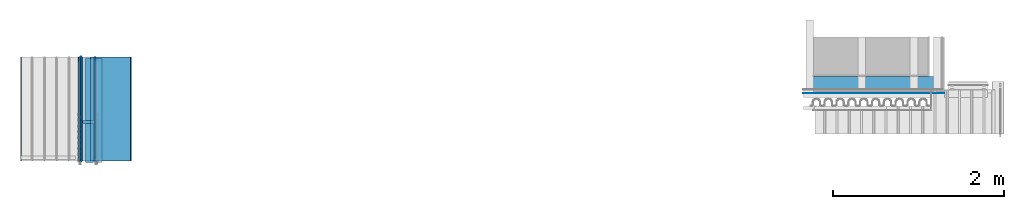
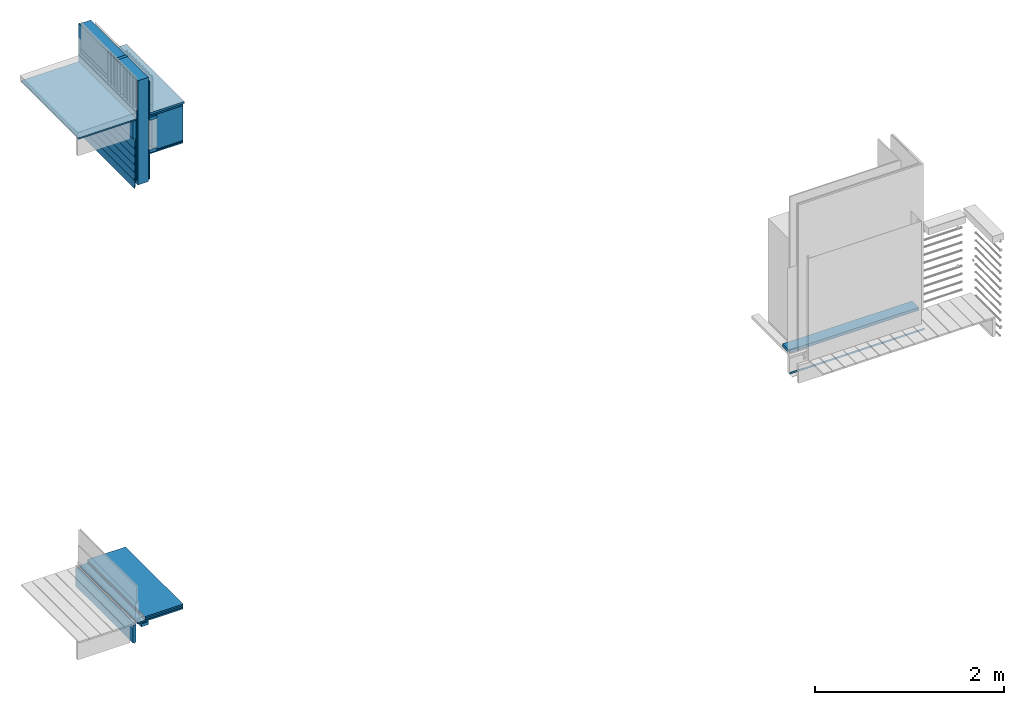
# One storey, part 1 of 33: 29 walls.
"""IFC4 building model written with IfcOpenShell, lengths in feet."""

from ifc_helpers import new_model, entity, si_unit, converted_unit, derived_unit, direction, frame, frame_2d, origin, origin_2d_with_axis, place, context, subcontext, project, spatial, rectangle, extrude, material, type_object, element, save


model = new_model("IFC4")

# Units and contexts
model_context = context("Model", 3, precision=0.0001, world=origin(), true_north=direction((6.12303176911189e-17, 1.0)))
body_context = subcontext(model_context, "Body", "Model", "MODEL_VIEW")
ifc_project = project(units=[converted_unit("LENGTHUNIT", "FOOT", entity("IfcRatioMeasure", 0.3048), si_unit("LENGTHUNIT", "METRE"), dimensions=[1, 0, 0, 0, 0, 0, 0]), converted_unit("AREAUNIT", "SQUARE FOOT", entity("IfcRatioMeasure", 0.09290304), si_unit("AREAUNIT", "SQUARE_METRE"), dimensions=[2, 0, 0, 0, 0, 0, 0]), converted_unit("VOLUMEUNIT", "CUBIC FOOT", entity("IfcRatioMeasure", 0.028316846592), si_unit("VOLUMEUNIT", "CUBIC_METRE"), dimensions=[3, 0, 0, 0, 0, 0, 0]), converted_unit("PLANEANGLEUNIT", "DEGREE", entity("IfcRatioMeasure", 0.0174532925199433), si_unit("PLANEANGLEUNIT", "RADIAN"), dimensions=[0, 0, 0, 0, 0, 0, 0]), si_unit("MASSUNIT", "GRAM", prefix="KILO"), derived_unit("MASSDENSITYUNIT", [(si_unit("MASSUNIT", "GRAM", prefix="KILO"), 1), (si_unit("LENGTHUNIT", "METRE"), -3)]), derived_unit("MOMENTOFINERTIAUNIT", [(si_unit("LENGTHUNIT", "METRE"), 4)]), si_unit("TIMEUNIT", "SECOND"), si_unit("FREQUENCYUNIT", "HERTZ"), si_unit("THERMODYNAMICTEMPERATUREUNIT", "DEGREE_CELSIUS"), derived_unit("THERMALTRANSMITTANCEUNIT", [(si_unit("MASSUNIT", "GRAM", prefix="KILO"), 1), (si_unit("THERMODYNAMICTEMPERATUREUNIT", "KELVIN"), -1), (si_unit("TIMEUNIT", "SECOND"), -3)]), derived_unit("VOLUMETRICFLOWRATEUNIT", [(si_unit("LENGTHUNIT", "METRE"), 3), (si_unit("TIMEUNIT", "SECOND"), -1)]), si_unit("ELECTRICCURRENTUNIT", "AMPERE"), si_unit("ELECTRICVOLTAGEUNIT", "VOLT"), si_unit("POWERUNIT", "WATT"), si_unit("FORCEUNIT", "NEWTON"), si_unit("ILLUMINANCEUNIT", "LUX"), si_unit("LUMINOUSFLUXUNIT", "LUMEN"), si_unit("LUMINOUSINTENSITYUNIT", "CANDELA"), derived_unit("USERDEFINED", [(si_unit("MASSUNIT", "GRAM", prefix="KILO"), -1), (si_unit("LENGTHUNIT", "METRE"), -2), (si_unit("TIMEUNIT", "SECOND"), 3), (si_unit("LUMINOUSFLUXUNIT", "LUMEN"), 1)]), derived_unit("LINEARVELOCITYUNIT", [(si_unit("LENGTHUNIT", "METRE"), 1), (si_unit("TIMEUNIT", "SECOND"), -1)]), si_unit("PRESSUREUNIT", "PASCAL"), derived_unit("USERDEFINED", [(si_unit("LENGTHUNIT", "METRE"), -2), (si_unit("MASSUNIT", "GRAM", prefix="KILO"), 1), (si_unit("TIMEUNIT", "SECOND"), -2)]), derived_unit("LINEARFORCEUNIT", [(si_unit("MASSUNIT", "GRAM", prefix="KILO"), 1), (si_unit("LENGTHUNIT", "METRE"), 1), (si_unit("TIMEUNIT", "SECOND"), -2), (si_unit("LENGTHUNIT", "METRE"), -1)]), derived_unit("PLANARFORCEUNIT", [(si_unit("MASSUNIT", "GRAM", prefix="KILO"), 1), (si_unit("LENGTHUNIT", "METRE"), 1), (si_unit("TIMEUNIT", "SECOND"), -2), (si_unit("LENGTHUNIT", "METRE"), -2)])], contexts=[model_context])

# Site, building, storey
site_placement = place(None, origin())
site = spatial("IfcSite", under=ifc_project, at=site_placement, CompositionType="ELEMENT")
building_placement = place(site_placement, origin())
building = spatial("IfcBuilding", under=site, at=building_placement, CompositionType="ELEMENT")
storey_placement = place(building_placement, frame((0.0, 0.0, 10.0)))
storey = spatial("IfcBuildingStorey", under=building, at=storey_placement, Name="2ND FLOOR", CompositionType="ELEMENT", Elevation=10.0000000000002)

# Walls
ifc_material_1 = material(Name="2X10 LEDGER - STAIN BEFORE INSTALL", Category="Materials")
wall_type_1 = type_object("IfcWallType", Name="Walls 14:Walls 13", PredefinedType="NOTDEFINED", material=ifc_material_1)
wall_1_placement = place(storey_placement, frame((1459.13314342118, 2.0, -0.136150105919342), z_axis=(0.0, 0.0, 1.0), x_axis=(0.0, 1.0, 0.0)))
element("IfcWall", 1, at=wall_1_placement, inside=storey, type_object=wall_type_1, material=ifc_material_1, Name="Walls 14:Walls 13", ObjectType="Walls 14:Walls 13", PredefinedType="NOTDEFINED", context=body_context, shape_type="SweptSolid", body=[
    extrude(rectangle(XDim=4.0, YDim=0.125, at=origin_2d_with_axis()), frame((2.0, -0.0625, 0.0)), (0.0, 0.0, 1.0), 0.749058960190016),
])
ifc_material_2 = material(Name="3/4 HARDWOOD FLOOR", Category="Materials")
wall_type_2 = type_object("IfcWallType", Name="Generic Models 624:Generic Models 1", PredefinedType="NOTDEFINED", material=ifc_material_2)
wall_2_placement = place(storey_placement, frame((1459.61600363951, 2.0, 0.749462449470961), z_axis=(0.0, 0.0, 1.0), x_axis=(0.0, 1.0, 0.0)))
element("IfcWall", 2, at=wall_2_placement, inside=storey, type_object=wall_type_2, material=ifc_material_2, Name="Generic Models 624:Generic Models 1", ObjectType="Generic Models 624:Generic Models 1", PredefinedType="NOTDEFINED", context=body_context, shape_type="SweptSolid", body=[
    extrude(rectangle(XDim=4.0, YDim=1.53135841010771, at=origin_2d_with_axis()), frame((2.0, -0.765679205053857, 0.0)), (0.0, 0.0, 1.0), 0.0625000000000053),
])
ifc_material_3 = material(Category="Materials")
wall_type_3 = type_object("IfcWallType", Name="Generic Models 642:Generic Models 1", PredefinedType="NOTDEFINED", material=ifc_material_3)
wall_3_placement = place(storey_placement, frame((1459.61600363951, 2.0, 0.686962449470574), z_axis=(0.0, 0.0, 1.0), x_axis=(0.0, 1.0, 0.0)))
element("IfcWall", 3, at=wall_3_placement, inside=storey, type_object=wall_type_3, material=ifc_material_3, Name="Generic Models 642:Generic Models 1", ObjectType="Generic Models 642:Generic Models 1", PredefinedType="NOTDEFINED", context=body_context, shape_type="SweptSolid", body=[
    extrude(rectangle(XDim=4.0, YDim=1.53135841010771, at=origin_2d_with_axis()), frame((2.0, -0.765679205053857, 0.0)), (0.0, 0.0, 1.0), 0.0625000000005151),
])
ifc_material_4 = material(Category="Materials")
wall_type_4 = type_object("IfcWallType", Name="Generic Models 644:Generic Models 1", PredefinedType="NOTDEFINED", material=ifc_material_4)
wall_4_placement = place(storey_placement, frame((1459.61138299712, 2.0, 0.669700544542543), z_axis=(0.0, 0.0, 1.0), x_axis=(0.0, 1.0, 0.0)))
element("IfcWall", 4, at=wall_4_placement, inside=storey, type_object=wall_type_4, material=ifc_material_4, Name="Generic Models 644:Generic Models 1", ObjectType="Generic Models 644:Generic Models 1", PredefinedType="NOTDEFINED", context=body_context, shape_type="SweptSolid", body=[
    extrude(rectangle(XDim=4.0, YDim=1.53597905249967, at=frame_2d((0.0, -1.13686837721616e-13), x_axis=(1.0, 0.0))), frame((2.0, -0.767989526249721, 0.0)), (0.0, 0.0, 1.0), 0.0104166666666679),
])
ifc_material_5 = material(Category="Materials")
wall_type_5 = type_object("IfcWallType", Name="Generic Models 659:Generic Models 1", PredefinedType="NOTDEFINED", material=ifc_material_5)
wall_5_placement = place(storey_placement, frame((1459.31114828999, 2.0, 0.604710198242904), z_axis=(0.0, 0.0, 1.0), x_axis=(0.0, 1.0, 0.0)))
element("IfcWall", 5, at=wall_5_placement, inside=storey, type_object=wall_type_5, material=ifc_material_5, Name="Generic Models 659:Generic Models 1", ObjectType="Generic Models 659:Generic Models 1", PredefinedType="NOTDEFINED", context=body_context, shape_type="SweptSolid", body=[
    extrude(rectangle(XDim=4.0, YDim=1.83621375963094, at=frame_2d((0.0, 2.27373675443232e-13), x_axis=(1.0, 0.0))), frame((2.0, -0.918106879815696, 0.0)), (0.0, 0.0, 1.0), 0.0625000000005169),
])
ifc_material_6 = material(Name="2X WOOD STUD", Category="Materials")
wall_type_6 = type_object("IfcWallType", Name="Generic Models 666:Generic Models 1", PredefinedType="NOTDEFINED", material=ifc_material_6)
wall_6_placement = place(storey_placement, frame((1459.31080872048, 3.44270833332939, 19.1970652408911)))
element("IfcWall", 6, at=wall_6_placement, inside=storey, type_object=wall_type_6, material=ifc_material_6, Name="Generic Models 666:Generic Models 1", ObjectType="Generic Models 666:Generic Models 1", PredefinedType="NOTDEFINED", context=body_context, shape_type="SweptSolid", body=[
    extrude(rectangle(XDim=0.125000000000001, YDim=0.458333333333485, at=frame_2d((-4.44089209850063e-16, 0.0), x_axis=(1.0, 0.0))), frame((0.229166666666742, 0.0625000000000022, 0.0), z_axis=(0.0, 0.0, 1.0), x_axis=(0.0, 1.0, 0.0)), (0.0, 0.0, 1.0), 4.4188083397401),
])
ifc_material_7 = material(Category="Materials")
wall_type_7 = type_object("IfcWallType", Name="Generic Models 701:Generic Models 1", PredefinedType="NOTDEFINED", material=ifc_material_7)
wall_7_placement = place(storey_placement, frame((1459.8987276705, 2.0, 20.4539793178762), z_axis=(0.0, 0.0, 1.0), x_axis=(0.0, 1.0, 0.0)))
element("IfcWall", 7, at=wall_7_placement, inside=storey, type_object=wall_type_7, material=ifc_material_7, Name="Generic Models 701:Generic Models 1", ObjectType="Generic Models 701:Generic Models 1", PredefinedType="NOTDEFINED", context=body_context, shape_type="SweptSolid", body=[
    extrude(rectangle(XDim=3.99999999999999, YDim=1.24863437911949, at=frame_2d((4.44089209850063e-16, -1.13686837721616e-13), x_axis=(1.0, 0.0))), frame((2.0, -0.624317189559633, 0.0)), (0.0, 0.0, 1.0), 1.47533404831026),
])
ifc_material_8 = material(Category="Materials")
wall_type_8 = type_object("IfcWallType", Name="Generic Models 702:Generic Models 1", PredefinedType="NOTDEFINED", material=ifc_material_8)
wall_8_placement = place(storey_placement, frame((1459.76914205382, 2.0, 19.2803985742244), z_axis=(0.0, 0.0, 1.0), x_axis=(0.0, 1.0, 0.0)))
element("IfcWall", 8, at=wall_8_placement, inside=storey, type_object=wall_type_8, material=ifc_material_8, Name="Generic Models 702:Generic Models 1", ObjectType="Generic Models 702:Generic Models 1", PredefinedType="NOTDEFINED", context=body_context, shape_type="SweptSolid", body=[
    extrude(rectangle(XDim=4.0, YDim=0.0520833333334849, at=frame_2d((2.22044604925031e-16, 0.0), x_axis=(1.0, 0.0))), frame((2.0, -0.0260416666667425, 0.0)), (0.0, 0.0, 1.0), 1.15710142577515),
])
wall_type_9 = type_object("IfcWallType", Name="Walls 17:Walls 13", PredefinedType="NOTDEFINED", material=ifc_material_1)
wall_9_placement = place(storey_placement, frame((1459.13314342118, 2.0, 21.2090806846188), z_axis=(0.0, 0.0, 1.0), x_axis=(0.0, 1.0, 0.0)))
element("IfcWall", 9, at=wall_9_placement, inside=storey, type_object=wall_type_9, material=ifc_material_1, Name="Walls 17:Walls 13", ObjectType="Walls 17:Walls 13", PredefinedType="NOTDEFINED", context=body_context, shape_type="SweptSolid", body=[
    extrude(rectangle(XDim=4.0, YDim=0.125, at=frame_2d((-2.22044604925031e-16, 0.0), x_axis=(1.0, 0.0))), frame((2.0, -0.0625, 0.0)), (0.0, 0.0, 1.0), 0.749058960190016),
])
ifc_material_9 = material(Category="Materials")
wall_type_10 = type_object("IfcWallType", Name="Generic Models 709:Generic Models 1", PredefinedType="NOTDEFINED", material=ifc_material_9)
wall_10_placement = place(storey_placement, frame((1459.81080872048, 2.0, 22.0005435315769), z_axis=(0.0, 0.0, 1.0), x_axis=(0.0, 1.0, 0.0)))
element("IfcWall", 10, at=wall_10_placement, inside=storey, type_object=wall_type_10, material=ifc_material_9, Name="Generic Models 709:Generic Models 1", ObjectType="Generic Models 709:Generic Models 1", PredefinedType="NOTDEFINED", context=body_context, shape_type="SweptSolid", body=[
    extrude(rectangle(XDim=4.0, YDim=1.37821999580547, at=frame_2d((2.22044604925031e-16, 0.0), x_axis=(1.0, 0.0))), frame((2.0, -0.689109997902733, 0.0)), (0.0, 0.0, 1.0), 0.0833333333333286),
])
ifc_material_10 = material(Name="FIBER CEMENT", Category="Materials")
wall_type_11 = type_object("IfcWallType", Name="Generic Models 717:Generic Models 1", PredefinedType="NOTDEFINED", material=ifc_material_10)
wall_11_placement = place(storey_placement, frame((1459.1949158051, 2.0, 20.7589183669021), z_axis=(0.0, 0.0, 1.0), x_axis=(0.0, 1.0, 0.0)))
element("IfcWall", 11, at=wall_11_placement, inside=storey, type_object=wall_type_11, material=ifc_material_10, Name="Generic Models 717:Generic Models 1", ObjectType="Generic Models 717:Generic Models 1", PredefinedType="NOTDEFINED", context=body_context, shape_type="SweptSolid", body=[
    extrude(rectangle(XDim=0.0259999999998033, YDim=4.0, at=frame_2d((1.11022302462516e-16, 0.0), x_axis=(0.0, 1.0))), frame((2.0, -0.0129531737923116, 0.0011024013350962), z_axis=(0.0, -0.0848001027000761, 0.99639798403151), x_axis=(1.0, 0.0, 0.0)), (0.0, 0.0, 1.0), 0.437499999999988),
])
ifc_material_11 = material(Category="Materials")
wall_type_12 = type_object("IfcWallType", Name="Generic Models 722:Generic Models 1", PredefinedType="NOTDEFINED", material=ifc_material_11)
wall_12_placement = place(storey_placement, frame((1459.82122538715, 2.0, 20.343749999999), z_axis=(0.0, 0.0, 1.0), x_axis=(0.0, 1.0, 0.0)))
element("IfcWall", 12, at=wall_12_placement, inside=storey, type_object=wall_type_12, material=ifc_material_11, Name="Generic Models 722:Generic Models 1", ObjectType="Generic Models 722:Generic Models 1", PredefinedType="NOTDEFINED", context=body_context, shape_type="SweptSolid", body=[
    extrude(rectangle(XDim=4.0, YDim=1.32613666247244, at=frame_2d((2.22044604925031e-16, 0.0), x_axis=(1.0, 0.0))), frame((2.0, -0.663068331236218, 0.0)), (0.0, 0.0, 1.0), 0.0520833333333712),
])
ifc_material_12 = material(Category="Materials")
wall_type_13 = type_object("IfcWallType", Name="Generic Models 723:Generic Models 1", PredefinedType="NOTDEFINED", material=ifc_material_12)
wall_13_placement = place(storey_placement, frame((1459.26914205382, 2.0, 19.4172960314291), z_axis=(0.0, 0.0, 1.0), x_axis=(0.0, 1.0, 0.0)))
element("IfcWall", 13, at=wall_13_placement, inside=storey, type_object=wall_type_13, material=ifc_material_12, Name="Generic Models 723:Generic Models 1", ObjectType="Generic Models 723:Generic Models 1", PredefinedType="NOTDEFINED", context=body_context, shape_type="SweptSolid", body=[
    extrude(rectangle(XDim=4.0, YDim=0.0416666666667425, at=frame_2d((-4.44089209850063e-16, -1.13686837721616e-13), x_axis=(1.0, 0.0))), frame((2.0, -0.0208333333332575, 0.0)), (0.0, 0.0, 1.0), 4.2248209060622),
])
ifc_material_13 = material(Name="BATT INSULATION - FILL CAVITY", Category="Materials")
wall_type_14 = type_object("IfcWallType", Name="Generic Models 724:Generic Models 1", PredefinedType="NOTDEFINED", material=ifc_material_13)
wall_14_placement = place(storey_placement, frame((1459.33173871609, 2.0, 19.1970652408911), z_axis=(0.0, 0.0, 1.0), x_axis=(0.0, 1.0, 0.0)))
element("IfcWall", 14, at=wall_14_placement, inside=storey, type_object=wall_type_14, material=ifc_material_13, Name="Generic Models 724:Generic Models 1", ObjectType="Generic Models 724:Generic Models 1", PredefinedType="NOTDEFINED", context=body_context, shape_type="SweptSolid", body=[
    extrude(rectangle(XDim=4.00000000000001, YDim=0.416570004389314, at=frame_2d((-4.44089209850063e-16, -1.13686837721616e-13), x_axis=(1.0, 0.0))), frame((2.0, -0.208285002194543, 0.0)), (0.0, 0.0, 1.0), 4.41880833974011),
])
ifc_material_14 = material(Category="Materials")
wall_type_15 = type_object("IfcWallType", Name="Generic Models 729:Generic Models 1", PredefinedType="NOTDEFINED", material=ifc_material_14)
wall_15_placement = place(storey_placement, frame((1459.82122538715, 2.0, 20.3958333333324), z_axis=(0.0, 0.0, 1.0), x_axis=(0.0, 1.0, 0.0)))
element("IfcWall", 15, at=wall_15_placement, inside=storey, type_object=wall_type_15, material=ifc_material_14, Name="Generic Models 729:Generic Models 1", ObjectType="Generic Models 729:Generic Models 1", PredefinedType="NOTDEFINED", context=body_context, shape_type="SweptSolid", body=[
    extrude(rectangle(XDim=4.0, YDim=1.32613666247244, at=frame_2d((2.22044604925031e-16, 0.0), x_axis=(1.0, 0.0))), frame((2.0, -0.663068331236218, 0.0)), (0.0, 0.0, 1.0), 0.0416666666669343),
])
ifc_material_15 = material(Name="WOOD TRUSS - SEE STRUCT", Category="Materials")
wall_type_16 = type_object("IfcWallType", Name="Generic Models 730:Generic Models 1", PredefinedType="NOTDEFINED", material=ifc_material_15)
wall_16_placement = place(storey_placement, frame((1459.76937904727, 1.94270833332915, 20.4374999999994), z_axis=(0.0, 0.0, 1.0), x_axis=(0.0, 1.0, 0.0)))
element("IfcWall", 16, at=wall_16_placement, inside=storey, type_object=wall_type_16, material=ifc_material_15, Name="Generic Models 730:Generic Models 1", ObjectType="Generic Models 730:Generic Models 1", PredefinedType="NOTDEFINED", context=body_context, shape_type="SweptSolid", body=[
    extrude(rectangle(XDim=4.0, YDim=0.291666666666742, at=frame_2d((0.0, -1.13686837721616e-13), x_axis=(1.0, 0.0))), frame((2.0, -0.145833333333258, 0.0)), (0.0, 0.0, 1.0), 0.125),
])
wall_type_17 = type_object("IfcWallType", Name="Generic Models 732:Generic Models 1", PredefinedType="NOTDEFINED", material=ifc_material_15)
wall_17_placement = place(storey_placement, frame((1459.76937904727, 1.94270833332915, 21.8124999999994), z_axis=(0.0, 0.0, 1.0), x_axis=(0.0, 1.0, 0.0)))
element("IfcWall", 17, at=wall_17_placement, inside=storey, type_object=wall_type_17, material=ifc_material_15, Name="Generic Models 732:Generic Models 1", ObjectType="Generic Models 732:Generic Models 1", PredefinedType="NOTDEFINED", context=body_context, shape_type="SweptSolid", body=[
    extrude(rectangle(XDim=4.0, YDim=0.291666666666742, at=frame_2d((0.0, -1.13686837721616e-13), x_axis=(1.0, 0.0))), frame((2.0, -0.145833333333258, 0.0)), (0.0, 0.0, 1.0), 0.125),
])
wall_type_18 = type_object("IfcWallType", Name="Generic Models 733:Generic Models 1", PredefinedType="NOTDEFINED", material=ifc_material_5)
wall_18_placement = place(storey_placement, frame((1459.76937904727, 2.0, 21.9380435315764), z_axis=(0.0, 0.0, 1.0), x_axis=(0.0, 1.0, 0.0)))
element("IfcWall", 18, at=wall_18_placement, inside=storey, type_object=wall_type_18, material=ifc_material_5, Name="Generic Models 733:Generic Models 1", ObjectType="Generic Models 733:Generic Models 1", PredefinedType="NOTDEFINED", context=body_context, shape_type="SweptSolid", body=[
    extrude(rectangle(XDim=4.0, YDim=1.37798300235659, at=frame_2d((2.22044604925031e-16, -1.13686837721616e-13), x_axis=(1.0, 0.0))), frame((2.0, -0.68899150117818, 0.0)), (0.0, 0.0, 1.0), 0.062500000000508),
])
ifc_material_16 = material(Category="Materials")
wall_type_19 = type_object("IfcWallType", Name="Generic Models 662:Generic Models 1", PredefinedType="NOTDEFINED", material=ifc_material_16)
wall_19_placement = place(storey_placement, frame((1456.95945835455, 2.0, 21.9644119498207), z_axis=(0.0, 0.0, 1.0), x_axis=(0.0, 1.0, 0.0)))
element("IfcWall", 19, at=wall_19_placement, inside=storey, type_object=wall_type_19, material=ifc_material_16, Name="Generic Models 662:Generic Models 1", ObjectType="Generic Models 662:Generic Models 1", PredefinedType="NOTDEFINED", context=body_context, shape_type="SweptSolid", body=[
    extrude(rectangle(XDim=4.0, YDim=2.30968369926654, at=frame_2d((-2.22044604925031e-16, -1.13686837721616e-13), x_axis=(1.0, 0.0))), frame((2.0, -1.15484184963316, 0.0)), (0.0, 0.0, 1.0), 0.0625000000005222),
])
ifc_material_17 = material(Name="DRAINAGE WRAP - ASTM 2273", Category="Materials")
wall_type_20 = type_object("IfcWallType", Name="Generic Models 711:Generic Models 1", PredefinedType="NOTDEFINED", material=ifc_material_17)
wall_20_placement = place(storey_placement, frame((1459.26440565184, 2.0, 19.4172960314291), z_axis=(0.0, 0.0, 1.0), x_axis=(0.0, 1.0, 0.0)))
element("IfcWall", 20, at=wall_20_placement, inside=storey, type_object=wall_type_20, material=ifc_material_17, Name="Generic Models 711:Generic Models 1", ObjectType="Generic Models 711:Generic Models 1", PredefinedType="NOTDEFINED", context=body_context, shape_type="SweptSolid", body=[
    extrude(rectangle(XDim=4.0, YDim=0.0033333333333303, at=frame_2d((-2.22044604925031e-16, -1.13686837721616e-13), x_axis=(1.0, 0.0))), frame((2.0, -0.00166666666655146, 0.0)), (0.0, 0.0, 1.0), 2.53566749181724),
])
wall_type_21 = type_object("IfcWallType", Name="Generic Models 706:Generic Models 1", PredefinedType="NOTDEFINED", material=ifc_material_15)
wall_21_placement = place(storey_placement, frame((1459.43580872048, 1.94270833332914, 0.479166666666085), z_axis=(0.0, 0.0, 1.0), x_axis=(0.0, 1.0, 0.0)))
element("IfcWall", 21, at=wall_21_placement, inside=storey, type_object=wall_type_21, material=ifc_material_15, Name="Generic Models 706:Generic Models 1", ObjectType="Generic Models 706:Generic Models 1", PredefinedType="NOTDEFINED", context=body_context, shape_type="SweptSolid", body=[
    extrude(rectangle(XDim=4.0, YDim=0.291666666666515, at=frame_2d((3.33066907387547e-16, 0.0), x_axis=(1.0, 0.0))), frame((2.0, -0.145833333333258, 0.0)), (0.0, 0.0, 1.0), 0.124999999999998),
])
wall_type_22 = type_object("IfcWallType", Name="Generic Models 699:Generic Models 1", PredefinedType="NOTDEFINED", material=ifc_material_12)
wall_22_placement = place(storey_placement, frame((1459.76914205382, 2.0, 22.0005435315771), z_axis=(0.0, 0.0, 1.0), x_axis=(0.0, 1.0, 0.0)))
element("IfcWall", 22, at=wall_22_placement, inside=storey, type_object=wall_type_22, material=ifc_material_12, Name="Generic Models 699:Generic Models 1", ObjectType="Generic Models 699:Generic Models 1", PredefinedType="NOTDEFINED", context=body_context, shape_type="SweptSolid", body=[
    extrude(rectangle(XDim=4.0, YDim=0.0416666666667425, at=frame_2d((3.33066907387547e-16, 1.13686837721616e-13), x_axis=(1.0, 0.0))), frame((2.0, -0.0208333333334849, 0.0)), (0.0, 0.0, 1.0), 1.42134261537622),
])
wall_type_23 = type_object("IfcWallType", Name="Generic Models 700:Generic Models 1", PredefinedType="NOTDEFINED", material=ifc_material_10)
wall_23_placement = place(storey_placement, frame((1459.1949158051, 2.0, 20.4255850335687), z_axis=(0.0, 0.0, 1.0), x_axis=(0.0, 1.0, 0.0)))
element("IfcWall", 23, at=wall_23_placement, inside=storey, type_object=wall_type_23, material=ifc_material_10, Name="Generic Models 700:Generic Models 1", ObjectType="Generic Models 700:Generic Models 1", PredefinedType="NOTDEFINED", context=body_context, shape_type="SweptSolid", body=[
    extrude(rectangle(XDim=0.0259999999998033, YDim=4.0, at=frame_2d((1.11022302462516e-16, 0.0), x_axis=(0.0, 1.0))), frame((2.0, -0.0129531737923116, 0.00110240133509976), z_axis=(0.0, -0.0848001027000761, 0.99639798403151), x_axis=(1.0, 0.0, 0.0)), (0.0, 0.0, 1.0), 0.437499999999988),
])
wall_type_24 = type_object("IfcWallType", Name="Generic Models 710:Generic Models 1", PredefinedType="NOTDEFINED", material=ifc_material_10)
wall_24_placement = place(storey_placement, frame((1459.1949158051, 2.0, 20.0922517002354), z_axis=(0.0, 0.0, 1.0), x_axis=(0.0, 1.0, 0.0)))
element("IfcWall", 24, at=wall_24_placement, inside=storey, type_object=wall_type_24, material=ifc_material_10, Name="Generic Models 710:Generic Models 1", ObjectType="Generic Models 710:Generic Models 1", PredefinedType="NOTDEFINED", context=body_context, shape_type="SweptSolid", body=[
    extrude(rectangle(XDim=0.0259999999998033, YDim=4.0, at=frame_2d((1.11022302462516e-16, 0.0), x_axis=(0.0, 1.0))), frame((2.0, -0.0129531737923116, 0.0011024013350962), z_axis=(0.0, -0.0848001027000761, 0.99639798403151), x_axis=(1.0, 0.0, 0.0)), (0.0, 0.0, 1.0), 0.437499999999988),
])
wall_type_25 = type_object("IfcWallType", Name="Generic Models 712:Generic Models 1", PredefinedType="NOTDEFINED", material=ifc_material_10)
wall_25_placement = place(storey_placement, frame((1459.1949158051, 2.0, 19.7589183669021), z_axis=(0.0, 0.0, 1.0), x_axis=(0.0, 1.0, 0.0)))
element("IfcWall", 25, at=wall_25_placement, inside=storey, type_object=wall_type_25, material=ifc_material_10, Name="Generic Models 712:Generic Models 1", ObjectType="Generic Models 712:Generic Models 1", PredefinedType="NOTDEFINED", context=body_context, shape_type="SweptSolid", body=[
    extrude(rectangle(XDim=0.0259999999998033, YDim=4.0, at=frame_2d((1.11022302462516e-16, 0.0), x_axis=(0.0, 1.0))), frame((2.0, -0.0129531737923116, 0.00110240133509976), z_axis=(0.0, -0.0848001027000761, 0.99639798403151), x_axis=(1.0, 0.0, 0.0)), (0.0, 0.0, 1.0), 0.437499999999988),
])
wall_type_26 = type_object("IfcWallType", Name="Generic Models 713:Generic Models 1", PredefinedType="NOTDEFINED", material=ifc_material_10)
wall_26_placement = place(storey_placement, frame((1459.1949158051, 2.0, 19.4255850335687), z_axis=(0.0, 0.0, 1.0), x_axis=(0.0, 1.0, 0.0)))
element("IfcWall", 26, at=wall_26_placement, inside=storey, type_object=wall_type_26, material=ifc_material_10, Name="Generic Models 713:Generic Models 1", ObjectType="Generic Models 713:Generic Models 1", PredefinedType="NOTDEFINED", context=body_context, shape_type="SweptSolid", body=[
    extrude(rectangle(XDim=0.0259999999998033, YDim=4.0, at=frame_2d((1.11022302462516e-16, 0.0), x_axis=(0.0, 1.0))), frame((2.0, -0.0129531737923116, 0.0011024013350962), z_axis=(0.0, -0.0848001027000761, 0.99639798403151), x_axis=(1.0, 0.0, 0.0)), (0.0, 0.0, 1.0), 0.437499999999988),
])
wall_type_27 = type_object("IfcWallType", Name="Generic Models 714:Generic Models 1", PredefinedType="NOTDEFINED", material=ifc_material_10)
wall_27_placement = place(storey_placement, frame((1459.1949158051, 2.0, 19.0922517002354), z_axis=(0.0, 0.0, 1.0), x_axis=(0.0, 1.0, 0.0)))
element("IfcWall", 27, at=wall_27_placement, inside=storey, type_object=wall_type_27, material=ifc_material_10, Name="Generic Models 714:Generic Models 1", ObjectType="Generic Models 714:Generic Models 1", PredefinedType="NOTDEFINED", context=body_context, shape_type="SweptSolid", body=[
    extrude(rectangle(XDim=0.0259999999998033, YDim=4.0, at=frame_2d((1.11022302462516e-16, 0.0), x_axis=(0.0, 1.0))), frame((2.0, -0.0129531737923116, 0.00110240133509976), z_axis=(0.0, -0.0848001027000761, 0.99639798403151), x_axis=(1.0, 0.0, 0.0)), (0.0, 0.0, 1.0), 0.437499999999988),
])
ifc_material_18 = material(Name="2X WOOD JOISTS", Category="Materials")
wall_type_28 = type_object("IfcWallType", Name="Walls 32:Walls 13", PredefinedType="NOTDEFINED", material=ifc_material_18)
wall_28_placement = place(storey_placement, frame((1487.03961782017, 4.79237630160339, 0.677265764873553)))
element("IfcWall", 28, at=wall_28_placement, inside=storey, type_object=wall_type_28, material=ifc_material_18, Name="Walls 32:Walls 13", ObjectType="Walls 32:Walls 13", PredefinedType="NOTDEFINED", context=body_context, shape_type="SweptSolid", body=[
    extrude(rectangle(XDim=0.459160732422029, YDim=5.19270833333348, at=origin_2d_with_axis()), frame((2.59635416666674, 0.229580366211023, 0.0), z_axis=(0.0, 0.0, 1.0), x_axis=(0.0, 1.0, 0.0)), (0.0, 0.0, 1.0), 0.125000000000005),
])
ifc_material_19 = material(Name="METAL FLASHING - BLACK", Category="Materials")
wall_type_29 = type_object("IfcWallType", Name="Generic Models 753:Generic Models 1", PredefinedType="NOTDEFINED", material=ifc_material_19)
wall_29_placement = place(storey_placement, frame((1486.94745796881, 4.60672099718357, -0.0735231045635576)))
element("IfcWall", 29, at=wall_29_placement, inside=storey, type_object=wall_type_29, material=ifc_material_19, Name="Generic Models 753:Generic Models 1", ObjectType="Generic Models 753:Generic Models 1", PredefinedType="NOTDEFINED", context=body_context, shape_type="SweptSolid", body=[
    extrude(rectangle(XDim=5.40028794991576, YDim=0.00325520833333304, at=frame_2d((0.0, 8.88178419700125e-16), x_axis=(1.0, 0.0))), frame((2.70014397495788, 0.00162760416671137, 0.0)), (0.0, 0.0, 1.0), 0.0823000822329725),
])

save(model, "model.ifc")
